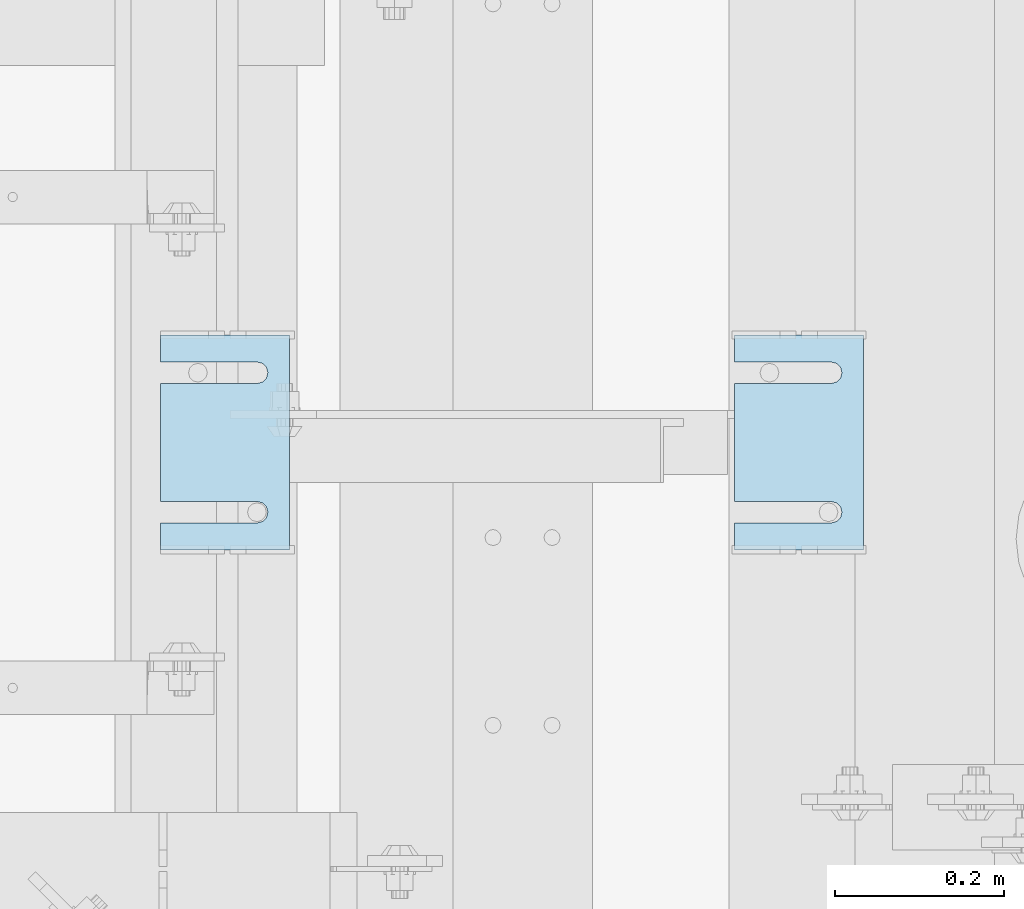
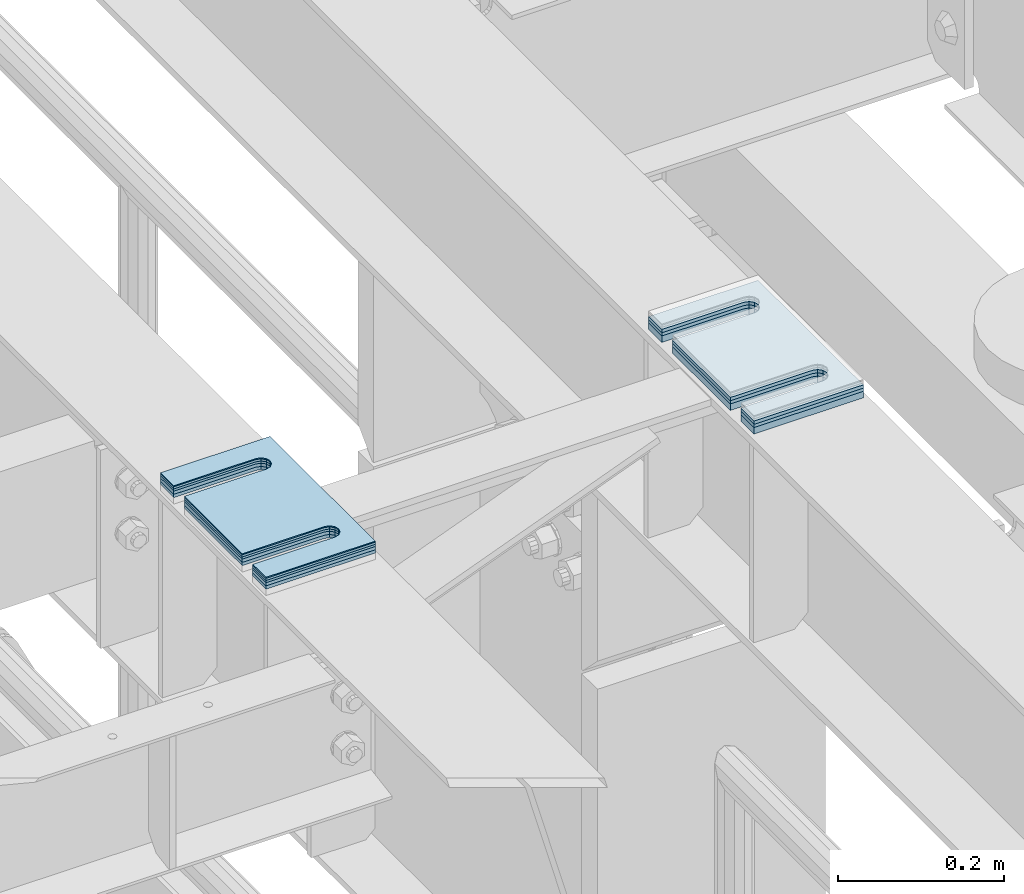
# One storey, part 1642 of 1876: 8 plates, 8 elements without a shape of their own.
"""IFC2X3 building model written with IfcOpenShell, lengths in millimetres."""

from ifc_helpers import new_model, si_unit, frame, origin_with_axes, place, context, subcontext, project, spatial, faceted_brep, material, type_object, element, aggregate, save


model = new_model("IFC2X3")

# Units and contexts
model_context = context("Model", 3, precision=1e-05, world=origin_with_axes())
body_context = subcontext(model_context, "Body", "Model", "MODEL_VIEW")
ifc_project = project(units=[si_unit("LENGTHUNIT", "METRE", prefix="MILLI"), si_unit("AREAUNIT", "SQUARE_METRE"), si_unit("VOLUMEUNIT", "CUBIC_METRE"), si_unit("MASSUNIT", "GRAM", prefix="KILO"), si_unit("TIMEUNIT", "SECOND"), si_unit("PLANEANGLEUNIT", "RADIAN"), si_unit("SOLIDANGLEUNIT", "STERADIAN"), si_unit("THERMODYNAMICTEMPERATUREUNIT", "DEGREE_CELSIUS"), si_unit("LUMINOUSINTENSITYUNIT", "LUMEN")], contexts=[model_context])

# Site, building, storey
site_placement = place(None, origin_with_axes())
site = spatial("IfcSite", under=ifc_project, at=site_placement, CompositionType="ELEMENT")
building_placement = place(site_placement, origin_with_axes())
building = spatial("IfcBuilding", under=site, at=building_placement, Name="Undefined", CompositionType="ELEMENT")
storey_placement = place(building_placement, origin_with_axes())
storey = spatial("IfcBuildingStorey", under=building, at=storey_placement, Name="Undefined", CompositionType="ELEMENT", Elevation=0.0)

# Assembly, plate
assembly_1_placement = place(storey_placement, origin_with_axes())
assembly_1 = element("IfcElementAssembly", 1, at=assembly_1_placement, inside=storey, Name="SHIM PLATE", AssemblyPlace="NOTDEFINED", PredefinedType="RIGID_FRAME")
ifc_material = material(Name="STEEL/A36")
plate_type_1 = type_object("IfcPlateType", PredefinedType="NOTDEFINED")
plate_1_placement = place(assembly_1_placement, frame((4899.26699394585, 3428.99813842841, 18009.3925), z_axis=(-1.0, 0.0, 0.0), x_axis=(0.0, 1.0, 0.0)))
plate_1 = element("IfcPlate", 2, at=plate_1_placement, type_object=plate_type_1, material=ifc_material, Name="SHIM PLATE", context=body_context, shape_type="Brep", body=[
    faceted_brep([(31.7473236467022, -0.793499999999767, 152.398895263674), (31.7495452849444, -0.793499999999767, 38.0994505459066), (31.7495452849444, 0.793499999999767, 38.0994505459066), (31.7473236467022, 0.793499999999767, 152.398895263674), (33.4510181364694, -0.793499999999767, 31.7494480392982), (33.4510181364694, 0.793499999999767, 31.7494480392982), (38.0995388011806, -0.793499999999767, 27.1009216783834), (38.0995388011806, 0.793499999999767, 27.1009216783834), (44.4495392228328, -0.793499999999767, 25.3994410457015), (44.4495392228328, 0.793499999999767, 25.3994410457015), (50.7995409628356, -0.793499999999767, 27.1009167582527), (50.7995409628356, 0.793499999999767, 27.1009167582527), (55.4480652293469, -0.793499999999767, 31.7494395173824), (55.4480652293469, 0.793499999999767, 31.7494395173824), (57.14954300102, -0.793499999999767, 38.0994407056476), (57.14954300102, 0.793499999999767, 38.0994407056476), (57.1473213626687, -0.793499999999767, 152.398894419415), (57.1473213626687, 0.793499999999767, 152.398895263676), (9.09494701772928e-13, -0.793499999999767, 0.0), (1.98268335225293e-05, -0.793499999999767, 152.398895263672), (1.98268335225293e-05, 0.793499999999767, 152.398895263672), (9.09494701772928e-13, 0.793499999999767, 0.0), (253.999542236328, -0.793499999999767, 6.16182660451159e-11), (253.999542236328, 0.793499999999767, 6.16182660451159e-11), (253.999557495107, -0.793499999999767, 152.398895263688), (253.999557495107, 0.793499999999767, 152.398895263688), (222.247321362667, 0.793499999999767, 152.398895263686), (222.247321362667, -0.793499999999767, 152.398895410166), (222.249543001019, 0.793499999999767, 38.0994416963979), (222.249543001019, -0.793499999999767, 38.0994416963979), (220.548065229345, 0.793499999999767, 31.7494405081325), (220.548065229345, -0.793499999999767, 31.7494405081325), (215.899540962834, 0.793499999999767, 27.100917749003), (215.899540962834, -0.793499999999767, 27.100917749003), (209.549539222831, 0.793499999999767, 25.3994420364518), (209.549539222831, -0.793499999999767, 25.3994420364518), (203.199538801179, 0.793499999999767, 27.1009226691335), (203.199538801179, -0.793499999999767, 27.1009226691335), (198.551018136468, 0.793499999999767, 31.7494490300483), (198.551018136468, -0.793499999999767, 31.7494490300483), (196.849545284943, 0.793499999999767, 38.0994515366567), (196.849545284943, -0.793499999999767, 38.0994515366567), (196.847323646701, -0.793499999999767, 152.398895263684), (196.847323646701, 0.793499999999767, 152.398895263684)], [[[0, 1, 2, 3]], [[4, 5, 2, 1]], [[6, 7, 5, 4]], [[8, 9, 7, 6]], [[10, 11, 9, 8]], [[12, 13, 11, 10]], [[14, 15, 13, 12]], [[16, 17, 15, 14]], [[18, 19, 20, 21]], [[22, 18, 21, 23]], [[24, 22, 23, 25]], [[24, 25, 26, 27]], [[27, 26, 28, 29]], [[29, 28, 30, 31]], [[31, 30, 32, 33]], [[33, 32, 34, 35]], [[35, 34, 36, 37]], [[37, 36, 38, 39]], [[39, 38, 40, 41]], [[42, 41, 40, 43]], [[12, 10, 8, 6, 4, 1, 0, 19, 18, 22, 24, 27, 29, 31, 33, 35, 37, 39, 41, 42, 16, 14]], [[20, 19, 0, 3]], [[43, 40, 38, 36, 34, 32, 30, 28, 26, 25, 23, 21, 20, 3, 2, 5, 7, 9, 11, 13, 15, 17]], [[42, 43, 17, 16]]]),
])
aggregate(assembly_1, [plate_1])

assembly_2_placement = place(storey_placement, origin_with_axes())
assembly_2 = element("IfcElementAssembly", 3, at=assembly_2_placement, inside=storey, Name="SHIM PLATE", AssemblyPlace="NOTDEFINED", PredefinedType="RIGID_FRAME")
plate_type_2 = type_object("IfcPlateType", PredefinedType="NOTDEFINED")
plate_2_placement = place(assembly_2_placement, frame((4899.26699394539, 3428.99813842828, 18007.0115), z_axis=(-1.0, 0.0, 0.0), x_axis=(0.0, 1.0, 0.0)))
plate_2 = element("IfcPlate", 4, at=plate_2_placement, type_object=plate_type_2, material=ifc_material, Name="SHIM PLATE", context=body_context, shape_type="Brep", body=[
    faceted_brep([(31.7473236467022, -1.58750000000146, 152.398895263674), (31.7495452849444, -1.58750000000146, 38.0994505459066), (31.7495452849444, 1.58750000000146, 38.0994505459066), (31.7473236467022, 1.58750000000146, 152.398895263674), (33.4510181364694, -1.58750000000146, 31.7494480392982), (33.4510181364694, 1.58750000000146, 31.7494480392982), (38.0995388011806, -1.58750000000146, 27.1009216783834), (38.0995388011806, 1.58750000000146, 27.1009216783834), (44.4495392228328, -1.58750000000146, 25.3994410457015), (44.4495392228328, 1.58750000000146, 25.3994410457015), (50.7995409628356, -1.58750000000146, 27.1009167582527), (50.7995409628356, 1.58750000000146, 27.1009167582527), (55.4480652293469, -1.58750000000146, 31.7494395173824), (55.4480652293469, 1.58750000000146, 31.7494395173824), (57.14954300102, -1.58750000000146, 38.0994407056476), (57.14954300102, 1.58750000000146, 38.0994407056476), (57.1473213626687, -1.58750000000146, 152.398894419415), (57.1473213626687, 1.58750000000146, 152.398895263676), (9.09494701772928e-13, -1.58750000000146, 4.54747350886464e-13), (1.98264133359771e-05, -1.58750000000146, 152.398895263672), (1.98264133359771e-05, 1.58750000000146, 152.398895263672), (9.09494701772928e-13, 1.58750000000146, 4.54747350886464e-13), (253.999542236328, -1.58750000000146, 6.16182660451159e-11), (253.999542236328, 1.58750000000146, 6.16182660451159e-11), (253.999557495107, -1.58750000000146, 152.398895263688), (253.999557495107, 1.58750000000146, 152.398895263688), (222.247321362667, 1.58750000000146, 152.398895263686), (222.247321362667, -1.58750000000146, 152.398895410166), (222.249543001019, 1.58750000000146, 38.0994416963979), (222.249543001019, -1.58750000000146, 38.0994416963979), (220.548065229345, 1.58750000000146, 31.7494405081325), (220.548065229345, -1.58750000000146, 31.7494405081325), (215.899540962834, 1.58750000000146, 27.100917749003), (215.899540962834, -1.58750000000146, 27.100917749003), (209.549539222831, 1.58750000000146, 25.3994420364518), (209.549539222831, -1.58750000000146, 25.3994420364518), (203.199538801179, 1.58750000000146, 27.1009226691335), (203.199538801179, -1.58750000000146, 27.1009226691335), (198.551018136468, 1.58750000000146, 31.7494490300483), (198.551018136468, -1.58750000000146, 31.7494490300483), (196.849545284943, 1.58750000000146, 38.0994515366567), (196.849545284943, -1.58750000000146, 38.0994515366567), (196.847323646701, -1.58750000000146, 152.398895263684), (196.847323646701, 1.58750000000146, 152.398895263684)], [[[0, 1, 2, 3]], [[4, 5, 2, 1]], [[6, 7, 5, 4]], [[8, 9, 7, 6]], [[10, 11, 9, 8]], [[12, 13, 11, 10]], [[14, 15, 13, 12]], [[16, 17, 15, 14]], [[18, 19, 20, 21]], [[22, 18, 21, 23]], [[24, 22, 23, 25]], [[24, 25, 26, 27]], [[27, 26, 28, 29]], [[29, 28, 30, 31]], [[31, 30, 32, 33]], [[33, 32, 34, 35]], [[35, 34, 36, 37]], [[37, 36, 38, 39]], [[39, 38, 40, 41]], [[42, 41, 40, 43]], [[12, 10, 8, 6, 4, 1, 0, 19, 18, 22, 24, 27, 29, 31, 33, 35, 37, 39, 41, 42, 16, 14]], [[20, 19, 0, 3]], [[43, 40, 38, 36, 34, 32, 30, 28, 26, 25, 23, 21, 20, 3, 2, 5, 7, 9, 11, 13, 15, 17]], [[42, 43, 17, 16]]]),
])
aggregate(assembly_2, [plate_2])

assembly_3_placement = place(storey_placement, origin_with_axes())
assembly_3 = element("IfcElementAssembly", 5, at=assembly_3_placement, inside=storey, Name="SHIM PLATE", AssemblyPlace="NOTDEFINED", PredefinedType="RIGID_FRAME")
plate_3_placement = place(assembly_3_placement, frame((4899.26699394493, 3428.99813842814, 18003.8365), z_axis=(-1.0, 0.0, 0.0), x_axis=(0.0, 1.0, 0.0)))
plate_3 = element("IfcPlate", 6, at=plate_3_placement, type_object=plate_type_2, material=ifc_material, Name="SHIM PLATE", context=body_context, shape_type="Brep", body=[
    faceted_brep([(31.7473236467022, -1.58750000000146, 152.398895263674), (31.7495452849444, -1.58750000000146, 38.0994505459066), (31.7495452849444, 1.58750000000146, 38.0994505459066), (31.7473236467022, 1.58750000000146, 152.398895263674), (33.4510181364694, -1.58750000000146, 31.7494480392982), (33.4510181364694, 1.58750000000146, 31.7494480392982), (38.0995388011806, -1.58750000000146, 27.1009216783834), (38.0995388011806, 1.58750000000146, 27.1009216783834), (44.4495392228328, -1.58750000000146, 25.3994410457015), (44.4495392228328, 1.58750000000146, 25.3994410457015), (50.7995409628356, -1.58750000000146, 27.1009167582527), (50.7995409628356, 1.58750000000146, 27.1009167582527), (55.4480652293469, -1.58750000000146, 31.7494395173824), (55.4480652293469, 1.58750000000146, 31.7494395173824), (57.14954300102, -1.58750000000146, 38.0994407056476), (57.14954300102, 1.58750000000146, 38.0994407056476), (57.1473213626687, -1.58750000000146, 152.398894419415), (57.1473213626687, 1.58750000000146, 152.398895263676), (9.09494701772928e-13, -1.58750000000146, 4.54747350886464e-13), (1.98264133359771e-05, -1.58750000000146, 152.398895263672), (1.98264133359771e-05, 1.58750000000146, 152.398895263672), (9.09494701772928e-13, 1.58750000000146, 4.54747350886464e-13), (253.999542236328, -1.58750000000146, 6.16182660451159e-11), (253.999542236328, 1.58750000000146, 6.16182660451159e-11), (253.999557495107, -1.58750000000146, 152.398895263688), (253.999557495107, 1.58750000000146, 152.398895263688), (222.247321362667, 1.58750000000146, 152.398895263686), (222.247321362667, -1.58750000000146, 152.398895410166), (222.249543001019, 1.58750000000146, 38.0994416963979), (222.249543001019, -1.58750000000146, 38.0994416963979), (220.548065229345, 1.58750000000146, 31.7494405081325), (220.548065229345, -1.58750000000146, 31.7494405081325), (215.899540962834, 1.58750000000146, 27.100917749003), (215.899540962834, -1.58750000000146, 27.100917749003), (209.549539222831, 1.58750000000146, 25.3994420364518), (209.549539222831, -1.58750000000146, 25.3994420364518), (203.199538801179, 1.58750000000146, 27.1009226691335), (203.199538801179, -1.58750000000146, 27.1009226691335), (198.551018136468, 1.58750000000146, 31.7494490300483), (198.551018136468, -1.58750000000146, 31.7494490300483), (196.849545284943, 1.58750000000146, 38.0994515366567), (196.849545284943, -1.58750000000146, 38.0994515366567), (196.847323646701, -1.58750000000146, 152.398895263684), (196.847323646701, 1.58750000000146, 152.398895263684)], [[[0, 1, 2, 3]], [[4, 5, 2, 1]], [[6, 7, 5, 4]], [[8, 9, 7, 6]], [[10, 11, 9, 8]], [[12, 13, 11, 10]], [[14, 15, 13, 12]], [[16, 17, 15, 14]], [[18, 19, 20, 21]], [[22, 18, 21, 23]], [[24, 22, 23, 25]], [[24, 25, 26, 27]], [[27, 26, 28, 29]], [[29, 28, 30, 31]], [[31, 30, 32, 33]], [[33, 32, 34, 35]], [[35, 34, 36, 37]], [[37, 36, 38, 39]], [[39, 38, 40, 41]], [[42, 41, 40, 43]], [[12, 10, 8, 6, 4, 1, 0, 19, 18, 22, 24, 27, 29, 31, 33, 35, 37, 39, 41, 42, 16, 14]], [[20, 19, 0, 3]], [[43, 40, 38, 36, 34, 32, 30, 28, 26, 25, 23, 21, 20, 3, 2, 5, 7, 9, 11, 13, 15, 17]], [[42, 43, 17, 16]]]),
])
aggregate(assembly_3, [plate_3])

assembly_4_placement = place(storey_placement, origin_with_axes())
assembly_4 = element("IfcElementAssembly", 7, at=assembly_4_placement, inside=storey, Name="SHIM PLATE", AssemblyPlace="NOTDEFINED", PredefinedType="RIGID_FRAME")
plate_type_3 = type_object("IfcPlateType", PredefinedType="NOTDEFINED")
plate_4_placement = place(assembly_4_placement, frame((5578.71798271354, 3428.99813842801, 17999.868), z_axis=(-1.0, 0.0, 0.0), x_axis=(0.0, 1.0, 0.0)))
plate_4 = element("IfcPlate", 8, at=plate_4_placement, type_object=plate_type_3, material=ifc_material, Name="SHIM PLATE", context=body_context, shape_type="Brep", body=[
    faceted_brep([(31.7473236467022, -2.38100000000122, 152.398895263674), (31.7495452849444, -2.38100000000122, 38.0994505459066), (31.7495452849444, 2.38100000000122, 38.0994505459066), (31.7473236467022, 2.38100000000122, 152.398895263674), (33.4510181364694, -2.38100000000122, 31.7494480392982), (33.4510181364694, 2.38100000000122, 31.7494480392982), (38.0995388011806, -2.38100000000122, 27.1009216783834), (38.0995388011806, 2.38100000000122, 27.1009216783834), (44.4495392228328, -2.38100000000122, 25.3994410457015), (44.4495392228328, 2.38100000000122, 25.3994410457015), (50.7995409628356, -2.38100000000122, 27.1009167582527), (50.7995409628356, 2.38100000000122, 27.1009167582527), (55.4480652293469, -2.38100000000122, 31.7494395173824), (55.4480652293469, 2.38100000000122, 31.7494395173824), (57.14954300102, -2.38100000000122, 38.0994407056476), (57.14954300102, 2.38100000000122, 38.0994407056476), (57.1473213626687, -2.38100000000122, 152.398894419415), (57.1473213626687, 2.38100000000122, 152.398895263676), (0.0, -2.38100000000122, 4.54747350886464e-13), (1.98259931494249e-05, -2.38100000000122, 152.398895263672), (1.98259931494249e-05, 2.38100000000122, 152.398895263672), (0.0, 2.38100000000122, 4.54747350886464e-13), (253.999542236328, -2.38100000000122, 6.16182660451159e-11), (253.999542236328, 2.38100000000122, 6.16182660451159e-11), (253.999557495107, -2.38100000000122, 152.398895263688), (253.999557495107, 2.38100000000122, 152.398895263688), (222.247321362667, 2.38100000000122, 152.398895263686), (222.247321362667, -2.38100000000122, 152.398895410166), (222.249543001019, 2.38100000000122, 38.0994416963979), (222.249543001019, -2.38100000000122, 38.0994416963979), (220.548065229345, 2.38100000000122, 31.7494405081325), (220.548065229345, -2.38100000000122, 31.7494405081325), (215.899540962834, 2.38100000000122, 27.100917749003), (215.899540962834, -2.38100000000122, 27.100917749003), (209.549539222831, 2.38100000000122, 25.3994420364518), (209.549539222831, -2.38100000000122, 25.3994420364518), (203.199538801179, 2.38100000000122, 27.1009226691335), (203.199538801179, -2.38100000000122, 27.1009226691335), (198.551018136468, 2.38100000000122, 31.7494490300483), (198.551018136468, -2.38100000000122, 31.7494490300483), (196.849545284943, 2.38100000000122, 38.0994515366567), (196.849545284943, -2.38100000000122, 38.0994515366567), (196.847323646701, -2.38100000000122, 152.398895263684), (196.847323646701, 2.38100000000122, 152.398895263684)], [[[0, 1, 2, 3]], [[4, 5, 2, 1]], [[6, 7, 5, 4]], [[8, 9, 7, 6]], [[10, 11, 9, 8]], [[12, 13, 11, 10]], [[14, 15, 13, 12]], [[16, 17, 15, 14]], [[18, 19, 20, 21]], [[22, 18, 21, 23]], [[24, 22, 23, 25]], [[24, 25, 26, 27]], [[27, 26, 28, 29]], [[29, 28, 30, 31]], [[31, 30, 32, 33]], [[33, 32, 34, 35]], [[35, 34, 36, 37]], [[37, 36, 38, 39]], [[39, 38, 40, 41]], [[42, 41, 40, 43]], [[12, 10, 8, 6, 4, 1, 0, 19, 18, 22, 24, 27, 29, 31, 33, 35, 37, 39, 41, 42, 16, 14]], [[20, 19, 0, 3]], [[43, 40, 38, 36, 34, 32, 30, 28, 26, 25, 23, 21, 20, 3, 2, 5, 7, 9, 11, 13, 15, 17]], [[42, 43, 17, 16]]]),
])
aggregate(assembly_4, [plate_4])

assembly_5_placement = place(storey_placement, origin_with_axes())
assembly_5 = element("IfcElementAssembly", 9, at=assembly_5_placement, inside=storey, Name="SHIM PLATE", AssemblyPlace="NOTDEFINED", PredefinedType="RIGID_FRAME")
plate_5_placement = place(assembly_5_placement, frame((5578.71798271308, 3428.99813842787, 17995.106), z_axis=(-1.0, 0.0, 0.0), x_axis=(0.0, 1.0, 0.0)))
plate_5 = element("IfcPlate", 10, at=plate_5_placement, type_object=plate_type_3, material=ifc_material, Name="SHIM PLATE", context=body_context, shape_type="Brep", body=[
    faceted_brep([(31.7473236467022, -2.38100000000122, 152.398895263674), (31.7495452849444, -2.38100000000122, 38.0994505459066), (31.7495452849444, 2.38100000000122, 38.0994505459066), (31.7473236467022, 2.38100000000122, 152.398895263674), (33.4510181364694, -2.38100000000122, 31.7494480392982), (33.4510181364694, 2.38100000000122, 31.7494480392982), (38.0995388011806, -2.38100000000122, 27.1009216783834), (38.0995388011806, 2.38100000000122, 27.1009216783834), (44.4495392228328, -2.38100000000122, 25.3994410457015), (44.4495392228328, 2.38100000000122, 25.3994410457015), (50.7995409628356, -2.38100000000122, 27.1009167582527), (50.7995409628356, 2.38100000000122, 27.1009167582527), (55.4480652293469, -2.38100000000122, 31.7494395173824), (55.4480652293469, 2.38100000000122, 31.7494395173824), (57.14954300102, -2.38100000000122, 38.0994407056476), (57.14954300102, 2.38100000000122, 38.0994407056476), (57.1473213626687, -2.38100000000122, 152.398894419415), (57.1473213626687, 2.38100000000122, 152.398895263676), (0.0, -2.38100000000122, 4.54747350886464e-13), (1.98259931494249e-05, -2.38100000000122, 152.398895263672), (1.98259931494249e-05, 2.38100000000122, 152.398895263672), (0.0, 2.38100000000122, 4.54747350886464e-13), (253.999542236328, -2.38100000000122, 6.16182660451159e-11), (253.999542236328, 2.38100000000122, 6.16182660451159e-11), (253.999557495107, -2.38100000000122, 152.398895263688), (253.999557495107, 2.38100000000122, 152.398895263688), (222.247321362667, 2.38100000000122, 152.398895263686), (222.247321362667, -2.38100000000122, 152.398895410166), (222.249543001019, 2.38100000000122, 38.0994416963979), (222.249543001019, -2.38100000000122, 38.0994416963979), (220.548065229345, 2.38100000000122, 31.7494405081325), (220.548065229345, -2.38100000000122, 31.7494405081325), (215.899540962834, 2.38100000000122, 27.100917749003), (215.899540962834, -2.38100000000122, 27.100917749003), (209.549539222831, 2.38100000000122, 25.3994420364518), (209.549539222831, -2.38100000000122, 25.3994420364518), (203.199538801179, 2.38100000000122, 27.1009226691335), (203.199538801179, -2.38100000000122, 27.1009226691335), (198.551018136468, 2.38100000000122, 31.7494490300483), (198.551018136468, -2.38100000000122, 31.7494490300483), (196.849545284943, 2.38100000000122, 38.0994515366567), (196.849545284943, -2.38100000000122, 38.0994515366567), (196.847323646701, -2.38100000000122, 152.398895263684), (196.847323646701, 2.38100000000122, 152.398895263684)], [[[0, 1, 2, 3]], [[4, 5, 2, 1]], [[6, 7, 5, 4]], [[8, 9, 7, 6]], [[10, 11, 9, 8]], [[12, 13, 11, 10]], [[14, 15, 13, 12]], [[16, 17, 15, 14]], [[18, 19, 20, 21]], [[22, 18, 21, 23]], [[24, 22, 23, 25]], [[24, 25, 26, 27]], [[27, 26, 28, 29]], [[29, 28, 30, 31]], [[31, 30, 32, 33]], [[33, 32, 34, 35]], [[35, 34, 36, 37]], [[37, 36, 38, 39]], [[39, 38, 40, 41]], [[42, 41, 40, 43]], [[12, 10, 8, 6, 4, 1, 0, 19, 18, 22, 24, 27, 29, 31, 33, 35, 37, 39, 41, 42, 16, 14]], [[20, 19, 0, 3]], [[43, 40, 38, 36, 34, 32, 30, 28, 26, 25, 23, 21, 20, 3, 2, 5, 7, 9, 11, 13, 15, 17]], [[42, 43, 17, 16]]]),
])
aggregate(assembly_5, [plate_5])

assembly_6_placement = place(storey_placement, origin_with_axes())
assembly_6 = element("IfcElementAssembly", 11, at=assembly_6_placement, inside=storey, Name="SHIM PLATE", AssemblyPlace="NOTDEFINED", PredefinedType="RIGID_FRAME")
plate_6_placement = place(assembly_6_placement, frame((4899.26699394446, 3428.99813842801, 17999.868), z_axis=(-1.0, 0.0, 0.0), x_axis=(0.0, 1.0, 0.0)))
plate_6 = element("IfcPlate", 12, at=plate_6_placement, type_object=plate_type_3, material=ifc_material, Name="SHIM PLATE", context=body_context, shape_type="Brep", body=[
    faceted_brep([(31.7473236467022, -2.38100000000122, 152.398895263674), (31.7495452849444, -2.38100000000122, 38.0994505459066), (31.7495452849444, 2.38100000000122, 38.0994505459066), (31.7473236467022, 2.38100000000122, 152.398895263674), (33.4510181364694, -2.38100000000122, 31.7494480392982), (33.4510181364694, 2.38100000000122, 31.7494480392982), (38.0995388011806, -2.38100000000122, 27.1009216783834), (38.0995388011806, 2.38100000000122, 27.1009216783834), (44.4495392228328, -2.38100000000122, 25.3994410457015), (44.4495392228328, 2.38100000000122, 25.3994410457015), (50.7995409628356, -2.38100000000122, 27.1009167582527), (50.7995409628356, 2.38100000000122, 27.1009167582527), (55.4480652293469, -2.38100000000122, 31.7494395173824), (55.4480652293469, 2.38100000000122, 31.7494395173824), (57.14954300102, -2.38100000000122, 38.0994407056476), (57.14954300102, 2.38100000000122, 38.0994407056476), (57.1473213626687, -2.38100000000122, 152.398894419415), (57.1473213626687, 2.38100000000122, 152.398895263676), (0.0, -2.38100000000122, 4.54747350886464e-13), (1.98259931494249e-05, -2.38100000000122, 152.398895263672), (1.98259931494249e-05, 2.38100000000122, 152.398895263672), (0.0, 2.38100000000122, 4.54747350886464e-13), (253.999542236328, -2.38100000000122, 6.16182660451159e-11), (253.999542236328, 2.38100000000122, 6.16182660451159e-11), (253.999557495107, -2.38100000000122, 152.398895263688), (253.999557495107, 2.38100000000122, 152.398895263688), (222.247321362667, 2.38100000000122, 152.398895263686), (222.247321362667, -2.38100000000122, 152.398895410166), (222.249543001019, 2.38100000000122, 38.0994416963979), (222.249543001019, -2.38100000000122, 38.0994416963979), (220.548065229345, 2.38100000000122, 31.7494405081325), (220.548065229345, -2.38100000000122, 31.7494405081325), (215.899540962834, 2.38100000000122, 27.100917749003), (215.899540962834, -2.38100000000122, 27.100917749003), (209.549539222831, 2.38100000000122, 25.3994420364518), (209.549539222831, -2.38100000000122, 25.3994420364518), (203.199538801179, 2.38100000000122, 27.1009226691335), (203.199538801179, -2.38100000000122, 27.1009226691335), (198.551018136468, 2.38100000000122, 31.7494490300483), (198.551018136468, -2.38100000000122, 31.7494490300483), (196.849545284943, 2.38100000000122, 38.0994515366567), (196.849545284943, -2.38100000000122, 38.0994515366567), (196.847323646701, -2.38100000000122, 152.398895263684), (196.847323646701, 2.38100000000122, 152.398895263684)], [[[0, 1, 2, 3]], [[4, 5, 2, 1]], [[6, 7, 5, 4]], [[8, 9, 7, 6]], [[10, 11, 9, 8]], [[12, 13, 11, 10]], [[14, 15, 13, 12]], [[16, 17, 15, 14]], [[18, 19, 20, 21]], [[22, 18, 21, 23]], [[24, 22, 23, 25]], [[24, 25, 26, 27]], [[27, 26, 28, 29]], [[29, 28, 30, 31]], [[31, 30, 32, 33]], [[33, 32, 34, 35]], [[35, 34, 36, 37]], [[37, 36, 38, 39]], [[39, 38, 40, 41]], [[42, 41, 40, 43]], [[12, 10, 8, 6, 4, 1, 0, 19, 18, 22, 24, 27, 29, 31, 33, 35, 37, 39, 41, 42, 16, 14]], [[20, 19, 0, 3]], [[43, 40, 38, 36, 34, 32, 30, 28, 26, 25, 23, 21, 20, 3, 2, 5, 7, 9, 11, 13, 15, 17]], [[42, 43, 17, 16]]]),
])
aggregate(assembly_6, [plate_6])

assembly_7_placement = place(storey_placement, origin_with_axes())
assembly_7 = element("IfcElementAssembly", 13, at=assembly_7_placement, inside=storey, Name="SHIM PLATE", AssemblyPlace="NOTDEFINED", PredefinedType="RIGID_FRAME")
plate_7_placement = place(assembly_7_placement, frame((4899.266993944, 3428.99813842787, 17995.106), z_axis=(-1.0, 0.0, 0.0), x_axis=(0.0, 1.0, 0.0)))
plate_7 = element("IfcPlate", 14, at=plate_7_placement, type_object=plate_type_3, material=ifc_material, Name="SHIM PLATE", context=body_context, shape_type="Brep", body=[
    faceted_brep([(31.7473236467022, -2.38100000000122, 152.398895263674), (31.7495452849444, -2.38100000000122, 38.0994505459066), (31.7495452849444, 2.38100000000122, 38.0994505459066), (31.7473236467022, 2.38100000000122, 152.398895263674), (33.4510181364694, -2.38100000000122, 31.7494480392982), (33.4510181364694, 2.38100000000122, 31.7494480392982), (38.0995388011806, -2.38100000000122, 27.1009216783834), (38.0995388011806, 2.38100000000122, 27.1009216783834), (44.4495392228328, -2.38100000000122, 25.3994410457015), (44.4495392228328, 2.38100000000122, 25.3994410457015), (50.7995409628356, -2.38100000000122, 27.1009167582527), (50.7995409628356, 2.38100000000122, 27.1009167582527), (55.4480652293469, -2.38100000000122, 31.7494395173824), (55.4480652293469, 2.38100000000122, 31.7494395173824), (57.14954300102, -2.38100000000122, 38.0994407056476), (57.14954300102, 2.38100000000122, 38.0994407056476), (57.1473213626687, -2.38100000000122, 152.398894419415), (57.1473213626687, 2.38100000000122, 152.398895263676), (0.0, -2.38100000000122, 4.54747350886464e-13), (1.98259931494249e-05, -2.38100000000122, 152.398895263672), (1.98259931494249e-05, 2.38100000000122, 152.398895263672), (0.0, 2.38100000000122, 4.54747350886464e-13), (253.999542236328, -2.38100000000122, 6.16182660451159e-11), (253.999542236328, 2.38100000000122, 6.16182660451159e-11), (253.999557495107, -2.38100000000122, 152.398895263688), (253.999557495107, 2.38100000000122, 152.398895263688), (222.247321362667, 2.38100000000122, 152.398895263686), (222.247321362667, -2.38100000000122, 152.398895410166), (222.249543001019, 2.38100000000122, 38.0994416963979), (222.249543001019, -2.38100000000122, 38.0994416963979), (220.548065229345, 2.38100000000122, 31.7494405081325), (220.548065229345, -2.38100000000122, 31.7494405081325), (215.899540962834, 2.38100000000122, 27.100917749003), (215.899540962834, -2.38100000000122, 27.100917749003), (209.549539222831, 2.38100000000122, 25.3994420364518), (209.549539222831, -2.38100000000122, 25.3994420364518), (203.199538801179, 2.38100000000122, 27.1009226691335), (203.199538801179, -2.38100000000122, 27.1009226691335), (198.551018136468, 2.38100000000122, 31.7494490300483), (198.551018136468, -2.38100000000122, 31.7494490300483), (196.849545284943, 2.38100000000122, 38.0994515366567), (196.849545284943, -2.38100000000122, 38.0994515366567), (196.847323646701, -2.38100000000122, 152.398895263684), (196.847323646701, 2.38100000000122, 152.398895263684)], [[[0, 1, 2, 3]], [[4, 5, 2, 1]], [[6, 7, 5, 4]], [[8, 9, 7, 6]], [[10, 11, 9, 8]], [[12, 13, 11, 10]], [[14, 15, 13, 12]], [[16, 17, 15, 14]], [[18, 19, 20, 21]], [[22, 18, 21, 23]], [[24, 22, 23, 25]], [[24, 25, 26, 27]], [[27, 26, 28, 29]], [[29, 28, 30, 31]], [[31, 30, 32, 33]], [[33, 32, 34, 35]], [[35, 34, 36, 37]], [[37, 36, 38, 39]], [[39, 38, 40, 41]], [[42, 41, 40, 43]], [[12, 10, 8, 6, 4, 1, 0, 19, 18, 22, 24, 27, 29, 31, 33, 35, 37, 39, 41, 42, 16, 14]], [[20, 19, 0, 3]], [[43, 40, 38, 36, 34, 32, 30, 28, 26, 25, 23, 21, 20, 3, 2, 5, 7, 9, 11, 13, 15, 17]], [[42, 43, 17, 16]]]),
])
aggregate(assembly_7, [plate_7])

assembly_8_placement = place(storey_placement, origin_with_axes())
assembly_8 = element("IfcElementAssembly", 15, at=assembly_8_placement, inside=storey, Name="SHIM PLATE", AssemblyPlace="NOTDEFINED", PredefinedType="RIGID_FRAME")
plate_type_4 = type_object("IfcPlateType", PredefinedType="NOTDEFINED")
plate_8_placement = place(assembly_8_placement, frame((5578.71798271261, 3428.99813842774, 17987.9625), z_axis=(-1.0, 0.0, 0.0), x_axis=(0.0, 1.0, 0.0)))
plate_8 = element("IfcPlate", 16, at=plate_8_placement, type_object=plate_type_4, material=ifc_material, Name="SHIM PLATE", context=body_context, shape_type="Brep", body=[
    faceted_brep([(31.7473236467022, -4.76250000000073, 152.398895263674), (31.7495452849444, -4.76250000000073, 38.0994505459066), (31.7495452849444, 4.76250000000073, 38.0994505459066), (31.7473236467022, 4.76250000000073, 152.398895263674), (33.4510181364694, -4.76250000000073, 31.7494480392982), (33.4510181364694, 4.76250000000073, 31.7494480392982), (38.0995388011806, -4.76250000000073, 27.1009216783834), (38.0995388011806, 4.76250000000073, 27.1009216783834), (44.4495392228328, -4.76250000000073, 25.3994410457015), (44.4495392228328, 4.76250000000073, 25.3994410457015), (50.7995409628356, -4.76250000000073, 27.1009167582527), (50.7995409628356, 4.76250000000073, 27.1009167582527), (55.4480652293469, -4.76250000000073, 31.7494395173824), (55.4480652293469, 4.76250000000073, 31.7494395173824), (57.14954300102, -4.76250000000073, 38.0994407056476), (57.14954300102, 4.76250000000073, 38.0994407056476), (57.1473213626687, -4.76250000000073, 152.398894419415), (57.1473213626687, 4.76250000000073, 152.398895263676), (0.0, -4.76249999999982, 0.0), (1.98255729628727e-05, -4.76250000000073, 152.398895263672), (1.98255729628727e-05, 4.76250000000073, 152.398895263672), (0.0, 4.76249999999982, 0.0), (253.999542236328, -4.76250000000073, 6.16182660451159e-11), (253.999542236328, 4.76250000000073, 6.16182660451159e-11), (253.999557495107, -4.76250000000073, 152.398895263688), (253.999557495107, 4.76250000000073, 152.398895263688), (222.247321362667, 4.76250000000073, 152.398895263686), (222.247321362667, -4.76250000000073, 152.398895410166), (222.249543001019, 4.76250000000073, 38.0994416963979), (222.249543001019, -4.76250000000073, 38.0994416963979), (220.548065229345, 4.76250000000073, 31.7494405081325), (220.548065229345, -4.76250000000073, 31.7494405081325), (215.899540962834, 4.76250000000073, 27.100917749003), (215.899540962834, -4.76250000000073, 27.100917749003), (209.549539222831, 4.76250000000073, 25.3994420364518), (209.549539222831, -4.76250000000073, 25.3994420364518), (203.199538801179, 4.76250000000073, 27.1009226691335), (203.199538801179, -4.76250000000073, 27.1009226691335), (198.551018136468, 4.76250000000073, 31.7494490300483), (198.551018136468, -4.76250000000073, 31.7494490300483), (196.849545284943, 4.76250000000073, 38.0994515366567), (196.849545284943, -4.76250000000073, 38.0994515366567), (196.847323646701, -4.76250000000073, 152.398895263684), (196.847323646701, 4.76250000000073, 152.398895263684)], [[[0, 1, 2, 3]], [[4, 5, 2, 1]], [[6, 7, 5, 4]], [[8, 9, 7, 6]], [[10, 11, 9, 8]], [[12, 13, 11, 10]], [[14, 15, 13, 12]], [[16, 17, 15, 14]], [[18, 19, 20, 21]], [[22, 18, 21, 23]], [[24, 22, 23, 25]], [[24, 25, 26, 27]], [[27, 26, 28, 29]], [[29, 28, 30, 31]], [[31, 30, 32, 33]], [[33, 32, 34, 35]], [[35, 34, 36, 37]], [[37, 36, 38, 39]], [[39, 38, 40, 41]], [[42, 41, 40, 43]], [[12, 10, 8, 6, 4, 1, 0, 19, 18, 22, 24, 27, 29, 31, 33, 35, 37, 39, 41, 42, 16, 14]], [[20, 19, 0, 3]], [[43, 40, 38, 36, 34, 32, 30, 28, 26, 25, 23, 21, 20, 3, 2, 5, 7, 9, 11, 13, 15, 17]], [[42, 43, 17, 16]]]),
])
aggregate(assembly_8, [plate_8])

save(model, "model.ifc")
